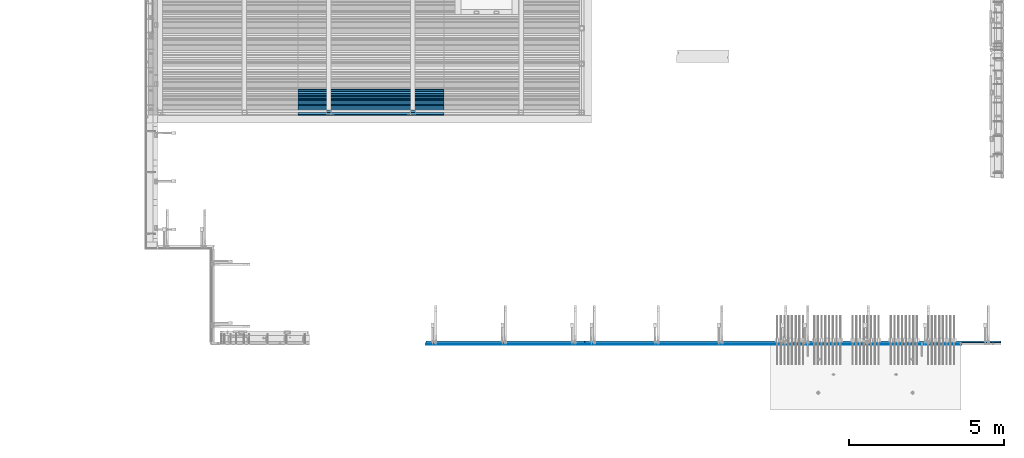
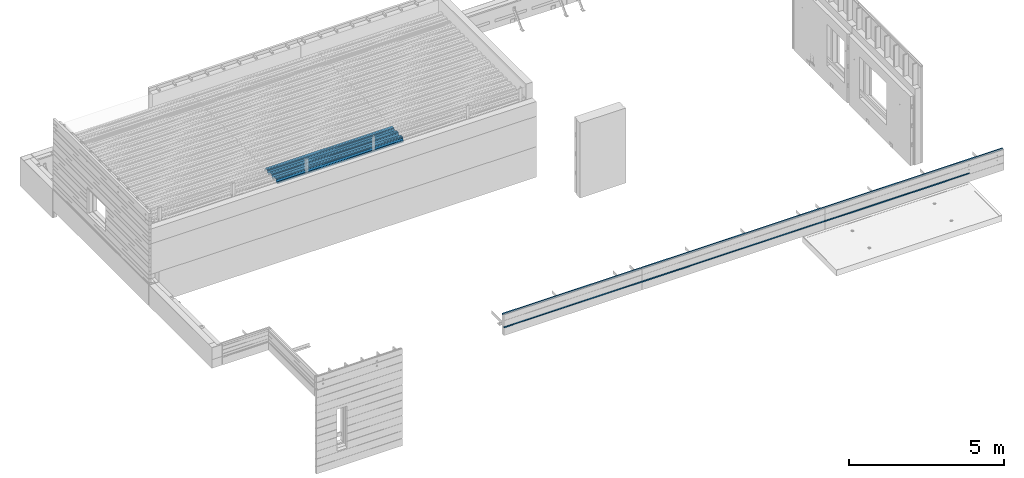
# One storey, part 19 of 153: 7 beams, 4 elements without a shape of their own.
"""IFC2X3 building model written with IfcOpenShell, lengths in millimetres."""

from ifc_helpers import new_model, si_unit, frame, origin_with_axes, place, context, subcontext, project, spatial, faceted_brep, material, type_object, element, aggregate, save


model = new_model("IFC2X3")

# Units and contexts
model_context = context("Model", 3, precision=1e-05, world=origin_with_axes())
body_context = subcontext(model_context, "Body", "Model", "MODEL_VIEW")
ifc_project = project(units=[si_unit("LENGTHUNIT", "METRE", prefix="MILLI"), si_unit("AREAUNIT", "SQUARE_METRE"), si_unit("VOLUMEUNIT", "CUBIC_METRE"), si_unit("MASSUNIT", "GRAM", prefix="KILO"), si_unit("TIMEUNIT", "SECOND"), si_unit("PLANEANGLEUNIT", "RADIAN"), si_unit("SOLIDANGLEUNIT", "STERADIAN"), si_unit("THERMODYNAMICTEMPERATUREUNIT", "DEGREE_CELSIUS"), si_unit("LUMINOUSINTENSITYUNIT", "LUMEN")], contexts=[model_context])

# Site, building, storey
site_placement = place(None, origin_with_axes())
site = spatial("IfcSite", under=ifc_project, at=site_placement, CompositionType="ELEMENT")
building_placement = place(site_placement, origin_with_axes())
building = spatial("IfcBuilding", under=site, at=building_placement, CompositionType="ELEMENT")
storey_placement = place(building_placement, origin_with_axes())
storey = spatial("IfcBuildingStorey", under=building, at=storey_placement, Name="8", CompositionType="ELEMENT", Elevation=0.0)

# Assembly, beam
assembly_1_placement = place(storey_placement, origin_with_axes())
assembly_1 = element("IfcElementAssembly", 1, at=assembly_1_placement, inside=storey, AssemblyPlace="NOTDEFINED", PredefinedType="REINFORCEMENT_UNIT")
ifc_material_1 = material(Name="TIMBER/T24")
beam_type_1 = type_object("IfcBeamType", PredefinedType="NOTDEFINED")
beam_1_placement = place(assembly_1_placement, frame((21800.0, 7562.5, 103080.0), z_axis=(0.0, -1.0, 0.0), x_axis=(-1.0, 3.00000001838171e-08, 0.0)))
beam_1 = element("IfcBeam", 2, at=beam_1_placement, type_object=beam_type_1, material=ifc_material_1, context=body_context, shape_type="Brep", body=[
    faceted_brep([(0.0, -25.0, -12.5), (5115.0, -25.0, -12.5), (5115.0, -6.41739461570978e-09, 12.5), (1.45519152283669e-11, -3.63797880709171e-12, 12.4999999999964), (0.0, 25.0, -12.5), (0.0, 25.0, 12.5), (5115.0, 25.0, 12.5), (5115.0, 25.0, -12.5)], [[[0, 1, 2, 3]], [[4, 5, 6, 7]], [[5, 4, 0, 3]], [[6, 5, 3, 2]], [[7, 6, 2, 1]], [[4, 7, 1, 0]]]),
])

assembly_2_placement = place(storey_placement, origin_with_axes())
assembly_2 = element("IfcElementAssembly", 3, at=assembly_2_placement, inside=storey, AssemblyPlace="NOTDEFINED", PredefinedType="REINFORCEMENT_UNIT")
beam_2_placement = place(assembly_2_placement, frame((28603.0, 7562.5, 103080.0), z_axis=(0.0, -1.0, 0.0), x_axis=(-1.0, 3.00000001838171e-08, 0.0)))
beam_2 = element("IfcBeam", 4, at=beam_2_placement, type_object=beam_type_1, material=ifc_material_1, context=body_context, shape_type="Brep", body=[
    faceted_brep([(0.0, -25.0, -12.5), (6788.0, -25.0, -12.5), (6788.0, -6.41739461570978e-09, 12.5), (1.45519152283669e-11, -3.63797880709171e-12, 12.4999999999964), (0.0, 25.0, -12.5), (0.0, 25.0, 12.5), (6788.0, 25.0, 12.5), (6788.0, 25.0, -12.5)], [[[0, 1, 2, 3]], [[4, 5, 6, 7]], [[5, 4, 0, 3]], [[6, 5, 3, 2]], [[7, 6, 2, 1]], [[4, 7, 1, 0]]]),
])

# Assembly, beams
assembly_3_placement = place(storey_placement, origin_with_axes())
assembly_3 = element("IfcElementAssembly", 5, at=assembly_3_placement, inside=storey, AssemblyPlace="NOTDEFINED", PredefinedType="REINFORCEMENT_UNIT")
beam_3_placement = place(assembly_3_placement, frame((33980.0, 7562.5, 103080.0), z_axis=(0.0, -1.0, 0.0), x_axis=(-1.0, 3.00000001838171e-08, 0.0)))
beam_3 = element("IfcBeam", 6, at=beam_3_placement, type_object=beam_type_1, material=ifc_material_1, context=body_context, shape_type="Brep", body=[
    faceted_brep([(0.0, -25.0, -12.5), (5363.0, -25.0, -12.5), (5363.0, -7.8580342233181e-09, 12.5), (1.45519152283669e-11, -3.63797880709171e-12, 12.4999999999964), (0.0, 25.0, -12.5), (0.0, 25.0, 12.5), (5363.0, 25.0, 12.5), (5363.0, 25.0, -12.5)], [[[0, 1, 2, 3]], [[4, 5, 6, 7]], [[5, 4, 0, 3]], [[6, 5, 3, 2]], [[7, 6, 2, 1]], [[4, 7, 1, 0]]]),
])
beam_type_2 = type_object("IfcBeamType", Name="PK50X50", PredefinedType="NOTDEFINED")
beam_4_placement = place(assembly_3_placement, frame((28617.0, 7640.0, 103545.0), z_axis=(0.0, 0.0, 1.0), x_axis=(1.0, 0.0, 0.0)))
beam_4 = element("IfcBeam", 7, at=beam_4_placement, type_object=beam_type_2, material=ifc_material_1, ObjectType="PK50X50", context=body_context, shape_type="Brep", body=[
    faceted_brep([(0.0, 25.0, 25.0), (0.0, -25.0, 25.0), (6643.0, -25.0, 25.0), (6643.0, 25.0, 25.0), (0.0, -25.0, -25.0), (6643.0, -25.0, -25.0), (0.0, 25.0, -25.0), (6643.0, 25.0, -25.0)], [[[0, 1, 2, 3]], [[1, 4, 5, 2]], [[4, 6, 7, 5]], [[6, 0, 3, 7]], [[5, 7, 3, 2]], [[4, 1, 0, 6]]]),
])
aggregate(assembly_3, [beam_3, beam_4])

# Beam
beam_5_placement = place(assembly_2_placement, frame((21815.0, 7640.0, 103545.0), z_axis=(0.0, 0.0, 1.0), x_axis=(1.0, 0.0, 0.0)))
beam_5 = element("IfcBeam", 8, at=beam_5_placement, type_object=beam_type_2, material=ifc_material_1, ObjectType="PK50X50", context=body_context, shape_type="Brep", body=[
    faceted_brep([(0.0, 25.0, 25.0), (0.0, -25.0, 25.0), (6788.0, -25.0, 25.0), (6788.0, 25.0, 25.0), (0.0, -25.0, -25.0), (6788.0, -25.0, -25.0), (0.0, 25.0, -25.0), (6788.0, 25.0, -25.0)], [[[0, 1, 2, 3]], [[1, 4, 5, 2]], [[4, 6, 7, 5]], [[6, 0, 3, 7]], [[5, 7, 3, 2]], [[4, 1, 0, 6]]]),
])

aggregate(assembly_2, [beam_2, beam_5])

beam_6_placement = place(assembly_1_placement, frame((16685.0, 7640.0, 103545.0), z_axis=(0.0, 0.0, 1.0), x_axis=(1.0, 0.0, 0.0)))
beam_6 = element("IfcBeam", 9, at=beam_6_placement, type_object=beam_type_2, material=ifc_material_1, ObjectType="PK50X50", context=body_context, shape_type="Brep", body=[
    faceted_brep([(0.0, 25.0, 25.0), (0.0, -25.0, 25.0), (5115.0, -25.0, 25.0), (5115.0, 25.0, 25.0), (0.0, -25.0, -25.0), (5115.0, -25.0, -25.0), (0.0, 25.0, -25.0), (5115.0, 25.0, -25.0)], [[[0, 1, 2, 3]], [[1, 4, 5, 2]], [[4, 6, 7, 5]], [[6, 0, 3, 7]], [[5, 7, 3, 2]], [[4, 1, 0, 6]]]),
])

aggregate(assembly_1, [beam_1, beam_6])

# Assembly, beam
assembly_4_placement = place(storey_placement, origin_with_axes())
assembly_4 = element("IfcElementAssembly", 10, at=assembly_4_placement, inside=storey, Name="Steel Assembly", AssemblyPlace="NOTDEFINED", PredefinedType="RIGID_FRAME")
ifc_material_2 = material(Name="STEEL/S355J2")
beam_type_3 = type_object("IfcBeamType", Name="W", PredefinedType="NOTDEFINED")
beam_7_placement = place(assembly_4_placement, frame((17251.9999999917, 15385.2090542417, 105749.900488301), z_axis=(0.0, -0.0124990270013869, 0.999921884110963), x_axis=(-1.0, 3.00000001838171e-08, 0.0)))
beam_7 = element("IfcBeam", 11, at=beam_7_placement, type_object=beam_type_3, material=ifc_material_2, ObjectType="W", context=body_context, shape_type="Brep", body=[
    faceted_brep([(0.0, -412.839996337891, -77.0100021362159), (0.0, -409.160003662109, -77.0100021362014), (4717.0, -409.160003662109, -77.0100021362159), (4717.0, -412.839996337891, -77.0100021362159), (0.0, -408.070007324222, -73.4800033569045), (4717.0, -408.070007324222, -73.480003356919), (0.0, -400.339996337894, -48.0600013732619), (4717.0, -400.339996337894, -48.0600013732765), (0.0, -399.459991455082, -46.5600013732619), (4717.0, -399.459991455078, -46.5600013732765), (0.0, -390.329986572269, -36.5499992370314), (4717.0, -390.329986572266, -36.549999237046), (0.0, -389.19000244141, -34.6300010680861), (4717.0, -389.190002441403, -34.6300010681007), (0.0, -367.820007324222, 35.3400001526024), (4717.0, -367.820007324219, 35.3400001525879), (0.0, -366.989990234379, 36.8499984741502), (4717.0, -366.989990234375, 36.8499984741356), (0.0, -357.809997558597, 46.8600006103807), (4717.0, -357.809997558594, 46.8600006103661), (0.0, -356.720001220707, 48.7700004577782), (4717.0, -356.720001220703, 48.7700004577782), (0.0, -349.309997558594, 73.1500015258935), (4717.0, -349.309997558594, 73.1500015258935), (0.0, -347.850006103516, 75.2300033569481), (4717.0, -347.850006103516, 75.2300033569481), (0.0, -345.470001220707, 76.010002136245), (4717.0, -345.470001220703, 76.0100021362305), (0.0, -305.480010986332, 76.010002136245), (4717.0, -305.480010986324, 76.0100021362305), (0.0, -304.279998779301, 75.8000030517578), (4717.0, -304.279998779301, 75.8000030517724), (0.0, -291.679992675785, 71.6999969482567), (4717.0, -291.679992675785, 71.6999969482567), (0.0, -290.179992675789, 71.2300033569481), (4717.0, -290.179992675781, 71.2300033569481), (0.0, -288.720001220707, 71.6999969482567), (4717.0, -288.720001220703, 71.6999969482422), (0.0, -276.119995117191, 75.8000030517869), (4717.0, -276.119995117188, 75.8000030517724), (0.0, -274.929992675785, 76.010002136245), (4717.0, -274.929992675785, 76.010002136245), (0.0, -234.94000244141, 76.010002136245), (4717.0, -234.94000244141, 76.010002136245), (0.0, -232.550003051758, 75.2300033569627), (4717.0, -232.550003051758, 75.2300033569481), (0.0, -231.100006103519, 73.1500015258935), (4717.0, -231.100006103516, 73.1500015258789), (0.0, -223.679992675785, 48.7700004577782), (4717.0, -223.679992675781, 48.7700004577782), (0.0, -222.589996337894, 46.8600006103661), (4717.0, -222.589996337891, 46.8600006103516), (0.0, -213.410003662113, 36.8499984741502), (4717.0, -213.410003662109, 36.8499984741356), (0.0, -212.529998779301, 35.3400001526024), (4717.0, -212.529998779297, 35.3400001526024), (0.0, -191.160003662109, -34.6300010681007), (4717.0, -191.160003662109, -34.6300010681007), (0.0, -190.070007324222, -36.5499992370605), (4717.0, -190.070007324215, -36.549999237046), (0.0, -180.940002441406, -46.560001373291), (4717.0, -180.940002441406, -46.5600013732765), (0.0, -180.059997558597, -48.0600013732619), (4717.0, -180.059997558594, -48.0600013732765), (0.0, -172.330001831055, -73.480003356919), (4717.0, -172.330001831055, -73.480003356919), (0.0, -171.240005493168, -77.0100021362159), (4717.0, -171.240005493164, -77.0100021362159), (0.0, -129.330001831062, -77.0100021362014), (4717.0, -129.330001831055, -77.0100021362159), (0.0, -128.300003051761, -73.480003356919), (4717.0, -128.300003051758, -73.4800033569336), (0.0, -120.51999664307, -48.0600013732765), (4717.0, -120.519996643063, -48.0600013732765), (0.0, -119.629997253418, -46.5600013732765), (4717.0, -119.629997253418, -46.5600013732765), (0.0, -110.500000000004, -36.5499992370314), (4717.0, -110.5, -36.549999237046), (0.0, -109.419998168949, -34.6300010680861), (4717.0, -109.419998168945, -34.6300010681007), (0.0, -88.0500030517615, 35.3400001526024), (4717.0, -88.0500030517578, 35.3400001526024), (0.0, -87.160003662113, 36.8499984741356), (4717.0, -87.160003662113, 36.8499984741356), (0.0, -78.0400009155273, 46.8600006103807), (4717.0, -78.0400009155273, 46.8600006103661), (0.0, -76.8899993896557, 48.7700004577782), (4717.0, -76.8899993896521, 48.7700004577782), (0.0, -69.4800033569336, 73.1500015258935), (4717.0, -69.4800033569336, 73.1500015258935), (0.0, -68.0299987793042, 75.2300033569336), (4717.0, -68.0299987792969, 75.2300033569481), (0.0, -65.6399993896521, 76.010002136245), (4717.0, -65.6399993896484, 76.010002136245), (0.0, -25.6499996185375, 76.0100021362596), (4717.0, -25.6499996185303, 76.010002136245), (0.0, -24.5100002288891, 75.8000030517724), (4717.0, -24.5100002288818, 75.8000030517724), (0.0, -11.8500003814697, 71.6999969482567), (4717.0, -11.8500003814661, 71.6999969482567), (0.0, -10.3999996185339, 71.2300033569481), (4717.0, -10.3999996185303, 71.2300033569336), (0.0, -8.89999961853391, 71.6999969482567), (4717.0, -8.89999961853391, 71.6999969482567), (0.0, 3.71000003814333, 75.8000030517724), (4717.0, 3.71000003814697, 75.8000030517869), (0.0, 4.90000009536379, 76.0100021362596), (4717.0, 4.90000009536379, 76.010002136245), (0.0, 44.8899993896484, 76.010002136245), (4717.0, 44.8899993896484, 76.010002136245), (0.0, 47.2799987792932, 75.2300033569481), (4717.0, 47.2799987792969, 75.2300033569481), (0.0, 48.6800003051721, 73.1500015258935), (4717.0, 48.6800003051758, 73.1500015258789), (0.0, 56.1500015258753, 48.7700004577782), (4717.0, 56.1500015258789, 48.7700004577782), (0.0, 57.2400016784632, 46.8600006103807), (4717.0, 57.2400016784632, 46.8600006103661), (0.0, 66.3700027465784, 36.8499984741211), (4717.0, 66.3700027465857, 36.8499984741356), (0.0, 67.2499999999964, 35.3400001526024), (4717.0, 67.2500000000036, 35.3400001526024), (0.0, 88.6200027465748, -34.6300010681007), (4717.0, 88.620002746582, -34.6300010681152), (0.0, 89.709999084469, -36.549999237046), (4717.0, 89.7099990844727, -36.5499992370605), (0.0, 98.8899993896412, -46.5600013732765), (4717.0, 98.8899993896484, -46.5600013732765), (0.0, 99.7699966430628, -48.0600013732765), (4717.0, 99.7699966430664, -48.060001373291), (0.0, 107.499999999996, -73.4800033569336), (4717.0, 107.5, -73.480003356919), (0.0, 108.589996337887, -77.0100021362014), (4717.0, 108.589996337894, -77.0100021362159), (0.0, 112.269996643063, -77.0100021362159), (4717.0, 112.269996643066, -77.0100021362159), (0.0, 146.759994506836, -77.0100021362159), (4717.0, 146.759994506836, -77.0100021362159), (0.0, 150.440002441403, -77.0100021362159), (4717.0, 150.440002441403, -77.0100021362305), (0.0, 151.529998779297, -73.480003356919), (4717.0, 151.529998779297, -73.4800033569336), (0.0, 159.30999755859, -48.0600013732765), (4717.0, 159.309997558594, -48.0600013732765), (0.0, 160.190002441406, -46.5600013732619), (4717.0, 160.190002441406, -46.5600013732765), (0.0, 169.320007324215, -36.549999237046), (4717.0, 169.320007324222, -36.5499992370605), (0.0, 170.410003662106, -34.6300010680861), (4717.0, 170.410003662109, -34.6300010681007), (0.0, 191.779998779293, 35.3400001526024), (4717.0, 191.779998779293, 35.3400001526024), (0.0, 192.660003662109, 36.8499984741502), (4717.0, 192.660003662109, 36.8499984741356), (0.0, 201.789993286129, 46.8600006103661), (4717.0, 201.789993286133, 46.8600006103661), (0.0, 202.880004882809, 48.7700004577637), (4717.0, 202.880004882813, 48.7700004577782), (0.0, 210.350006103512, 73.150001525908), (4717.0, 210.350006103516, 73.1500015258935), (0.0, 211.800003051754, 75.2300033569481), (4717.0, 211.800003051758, 75.2300033569336), (0.0, 214.190002441406, 76.010002136245), (4717.0, 214.19000244141, 76.010002136245), (0.0, 254.179992675778, 76.010002136245), (4717.0, 254.179992675778, 76.010002136245), (0.0, 255.320007324215, 75.8000030517869), (4717.0, 255.320007324222, 75.8000030517724), (0.0, 267.980010986324, 71.6999969482713), (4717.0, 267.980010986328, 71.6999969482567), (0.0, 269.429992675778, 71.2300033569481), (4717.0, 269.429992675781, 71.2300033569481), (0.0, 270.880004882809, 71.6999969482567), (4717.0, 270.880004882813, 71.6999969482567), (0.0, 283.540008544918, 75.8000030517869), (4717.0, 283.540008544918, 75.8000030517724), (0.0, 284.679992675778, 76.010002136245), (4717.0, 284.679992675778, 76.010002136245), (0.0, 324.670013427731, 76.010002136245), (4717.0, 324.670013427738, 76.010002136245), (0.0, 327.049987792969, 75.2300033569627), (4717.0, 327.049987792969, 75.2300033569481), (0.0, 328.510009765625, 73.1500015258789), (4717.0, 328.510009765625, 73.1500015258935), (0.0, 335.980010986324, 48.7700004577782), (4717.0, 335.980010986328, 48.7700004577782), (0.0, 337.05999755859, 46.8600006103661), (4717.0, 337.059997558594, 46.8600006103516), (0.0, 346.190002441399, 36.8499984741356), (4717.0, 346.190002441406, 36.8499984741211), (0.0, 347.079986572266, 35.3400001526024), (4717.0, 347.079986572266, 35.3400001526024), (0.0, 368.450012207028, -34.6300010680861), (4717.0, 368.450012207035, -34.6300010681007), (0.0, 369.529998779293, -36.5499992370314), (4717.0, 369.529998779297, -36.549999237046), (0.0, 378.660003662106, -46.5600013732619), (4717.0, 378.660003662106, -46.5600013732765), (0.0, 379.540008544918, -48.0600013732619), (4717.0, 379.540008544922, -48.0600013732765), (0.0, 387.329986572262, -73.480003356919), (4717.0, 387.329986572266, -73.4800033569045), (0.0, 388.410003662109, -77.0100021362159), (4717.0, 388.410003662109, -77.0100021362159), (0.0, 392.100006103512, -77.0100021362159), (4717.0, 392.100006103519, -77.0100021362159), (0.0, 426.589996337887, -77.0100021362159), (4717.0, 426.589996337891, -77.0100021362159), (0.0, 430.269989013668, -77.0100021362159), (4717.0, 430.269989013672, -77.0100021362305), (0.0, 431.359985351559, -73.4800033569045), (4717.0, 431.359985351563, -73.480003356919), (0.0, 433.179992675778, -67.5699996948097), (4717.0, 433.179992675781, -67.5699996948097), (0.0, 432.220001220699, -67.2699966430373), (4717.0, 432.220001220703, -67.2699966430519), (0.0, 430.410003662106, -73.1800003051612), (4717.0, 430.410003662106, -73.1800003051758), (0.0, 429.529998779293, -76.0100021362159), (4717.0, 429.529998779293, -76.0100021362159), (0.0, 426.589996337891, -76.0100021362159), (4717.0, 426.589996337891, -76.0100021362159), (0.0, 392.100006103512, -76.0100021362159), (4717.0, 392.100006103516, -76.0100021362159), (0.0, 389.149993896481, -76.0100021362014), (4717.0, 389.149993896484, -76.0100021362159), (0.0, 388.279998779293, -73.1800003051467), (4717.0, 388.279998779301, -73.1800003051612), (0.0, 380.470001220699, -47.659999847383), (4717.0, 380.470001220703, -47.6599998473976), (0.0, 379.470001220699, -45.9599990844436), (4717.0, 379.470001220703, -45.9599990844581), (0.0, 370.350006103512, -35.9599990844581), (4717.0, 370.350006103519, -35.9599990844581), (0.0, 369.369995117184, -34.2299995422218), (4717.0, 369.369995117184, -34.2299995422218), (0.0, 347.999999999996, 35.7500000000146), (4717.0, 348.0, 35.7500000000146), (0.0, 346.999999999996, 37.4399986267235), (4717.0, 347.000000000004, 37.4399986267235), (0.0, 337.880004882809, 47.450000762954), (4717.0, 337.880004882809, 47.4500007629395), (0.0, 336.899993896481, 49.1699981689453), (4717.0, 336.899993896484, 49.1699981689599), (0.0, 329.420013427731, 73.5999984741356), (4717.0, 329.420013427734, 73.5999984741356), (0.0, 327.679992675781, 76.0699996948533), (4717.0, 327.679992675781, 76.0699996948388), (0.0, 324.829986572262, 77.010002136245), (4717.0, 324.829986572266, 77.0100021362305), (0.0, 284.589996337887, 77.010002136245), (4717.0, 284.589996337891, 77.010002136245), (0.0, 283.290008544922, 76.769996643081), (4717.0, 283.290008544922, 76.769996643081), (0.0, 270.570007324215, 72.6500015258935), (4717.0, 270.570007324219, 72.6500015258935), (0.0, 269.429992675781, 72.2799987793114), (4717.0, 269.429992675781, 72.2799987793114), (0.0, 268.279998779293, 72.650001525908), (4717.0, 268.279998779297, 72.6500015258935), (0.0, 255.570007324219, 76.769996643081), (4717.0, 255.570007324219, 76.769996643081), (0.0, 254.270004272461, 77.0100021362596), (4717.0, 254.270004272461, 77.010002136245), (0.0, 214.029998779293, 77.0100021362596), (4717.0, 214.029998779297, 77.010002136245), (0.0, 211.179992675781, 76.0699996948388), (4717.0, 211.179992675781, 76.0699996948533), (0.0, 209.440002441403, 73.5999984741356), (4717.0, 209.44000244141, 73.5999984741211), (0.0, 201.960006713864, 49.1699981689599), (4717.0, 201.960006713867, 49.1699981689453), (0.0, 200.979995727532, 47.450000762954), (4717.0, 200.979995727539, 47.4500007629395), (0.0, 191.850006103508, 37.4399986267235), (4717.0, 191.850006103516, 37.439998626709), (0.0, 190.860000610352, 35.7500000000146), (4717.0, 190.860000610352, 35.75), (0.0, 169.49000549316, -34.2299995422218), (4717.0, 169.49000549316, -34.2299995422363), (0.0, 168.509994506832, -35.9599990844581), (4717.0, 168.509994506836, -35.9599990844581), (0.0, 159.380004882805, -45.9599990844436), (4717.0, 159.380004882813, -45.9599990844581), (0.0, 158.389999389645, -47.6599998473976), (4717.0, 158.389999389645, -47.6599998474121), (0.0, 150.580001831051, -73.1800003051612), (4717.0, 150.580001831058, -73.1800003051758), (0.0, 149.710006713864, -76.0100021362159), (4717.0, 149.710006713867, -76.0100021362159), (0.0, 146.759994506836, -76.0100021362159), (4717.0, 146.759994506836, -76.0100021362159), (0.0, 112.269996643063, -76.0100021362159), (4717.0, 112.269996643063, -76.0100021362159), (0.0, 109.319999694821, -76.0100021362159), (4717.0, 109.319999694821, -76.0100021362159), (0.0, 108.449996948239, -73.1900024413917), (4717.0, 108.449996948242, -73.1900024414063), (0.0, 100.690002441406, -47.659999847383), (4717.0, 100.69000244141, -47.6599998473976), (0.0, 99.6999969482386, -45.9599990844581), (4717.0, 99.6999969482422, -45.9599990844581), (0.0, 90.5199966430664, -35.9599990844581), (4717.0, 90.5199966430664, -35.9599990844727), (0.0, 89.5400009155273, -34.2299995422218), (4717.0, 89.5400009155273, -34.2299995422218), (0.0, 68.1699981689417, 35.7500000000146), (4717.0, 68.1699981689453, 35.7500000000146), (0.0, 67.1699981689417, 37.4399986267235), (4717.0, 67.1699981689453, 37.4399986267235), (0.0, 58.0499992370569, 47.4500007629686), (4717.0, 58.0499992370605, 47.450000762954), (0.0, 57.0699996948206, 49.1699981689599), (4717.0, 57.0699996948279, 49.1699981689453), (0.0, 49.5900001525843, 73.5899963379052), (4717.0, 49.5900001525879, 73.5899963378906), (0.0, 47.9099998474085, 76.0699996948388), (4717.0, 47.9099998474121, 76.0699996948242), (0.0, 45.0499992370569, 77.010002136245), (4717.0, 45.0499992370605, 77.010002136245), (0.0, 4.82000017165774, 77.010002136245), (4717.0, 4.82000017166138, 77.010002136245), (0.0, 3.47000002860659, 76.7699966430955), (4717.0, 3.47000002860659, 76.769996643081), (0.0, -9.19999980926514, 72.6500015258935), (4717.0, -9.19999980926514, 72.6500015258789), (0.0, -10.3900003433264, 72.2799987792969), (4717.0, -10.3900003433228, 72.2799987793114), (0.0, -11.5399999618567, 72.6500015258935), (4717.0, -11.5399999618494, 72.6500015258935), (0.0, -24.2600002288855, 76.769996643081), (4717.0, -24.2600002288818, 76.769996643081), (0.0, -25.559999465946, 77.0100021362596), (4717.0, -25.5599994659424, 77.010002136245), (0.0, -65.8000030517615, 77.0100021362596), (4717.0, -65.8000030517578, 77.010002136245), (0.0, -68.6500015258862, 76.0699996948533), (4717.0, -68.6500015258825, 76.0699996948388), (0.0, -70.3899993896521, 73.5999984741356), (4717.0, -70.3899993896484, 73.5999984741211), (0.0, -77.8199996948242, 49.1800003051903), (4717.0, -77.8199996948242, 49.1800003051903), (0.0, -78.8399963378943, 47.450000762954), (4717.0, -78.8399963378906, 47.4500007629395), (0.0, -87.9700012207031, 37.4399986267235), (4717.0, -87.9700012207031, 37.4399986267235), (0.0, -88.9700012207068, 35.7500000000146), (4717.0, -88.9700012207031, 35.75), (0.0, -110.339996337894, -34.2299995422218), (4717.0, -110.339996337887, -34.2299995422218), (0.0, -111.319999694828, -35.9599990844581), (4717.0, -111.319999694824, -35.9599990844581), (0.0, -120.440002441406, -45.9599990844436), (4717.0, -120.440002441406, -45.9599990844581), (0.0, -121.44000244141, -47.6599998473976), (4717.0, -121.440002441403, -47.6599998473976), (0.0, -129.250000000004, -73.1900024413771), (4717.0, -129.25, -73.1900024413917), (0.0, -130.080001831062, -76.0100021362159), (4717.0, -130.080001831055, -76.0100021362159), (0.0, -170.5, -76.0100021362014), (4717.0, -170.5, -76.0100021362159), (0.0, -171.380004882816, -73.1900024413917), (4717.0, -171.380004882813, -73.1900024414063), (0.0, -179.139999389652, -47.6599998473976), (4717.0, -179.139999389648, -47.6599998473976), (0.0, -180.130004882816, -45.9599990844581), (4717.0, -180.130004882813, -45.9599990844581), (0.0, -189.259994506836, -35.9599990844581), (4717.0, -189.259994506832, -35.9599990844581), (0.0, -190.240005493168, -34.2299995422218), (4717.0, -190.240005493164, -34.2299995422218), (0.0, -211.610000610355, 35.7500000000146), (4717.0, -211.610000610352, 35.7500000000146), (0.0, -212.600006103519, 37.4399986267381), (4717.0, -212.600006103519, 37.4399986267235), (0.0, -221.779998779301, 47.450000762954), (4717.0, -221.779998779293, 47.4500007629395), (0.0, -222.75999450684, 49.1699981689599), (4717.0, -222.759994506836, 49.1699981689599), (0.0, -230.190002441406, 73.5999984741356), (4717.0, -230.190002441406, 73.5999984741211), (0.0, -231.919998168945, 76.0699996948388), (4717.0, -231.919998168945, 76.0699996948388), (0.0, -234.779998779301, 77.010002136245), (4717.0, -234.779998779293, 77.010002136245), (0.0, -275.010009765629, 77.010002136245), (4717.0, -275.010009765625, 77.0100021362305), (0.0, -276.359985351563, 76.769996643081), (4717.0, -276.359985351563, 76.7699966430664), (0.0, -289.029998779297, 72.6500015258789), (4717.0, -289.029998779297, 72.6500015258935), (0.0, -290.179992675785, 72.2799987793114), (4717.0, -290.179992675785, 72.2799987793114), (0.0, -291.380004882816, 72.650001525908), (4717.0, -291.380004882813, 72.6500015258935), (0.0, -304.040008544926, 76.769996643081), (4717.0, -304.040008544918, 76.769996643081), (0.0, -305.390014648441, 77.010002136245), (4717.0, -305.390014648438, 77.010002136245), (0.0, -345.63000488282, 77.0100021362596), (4717.0, -345.630004882813, 77.010002136245), (0.0, -348.480010986332, 76.0699996948388), (4717.0, -348.480010986324, 76.0699996948388), (0.0, -350.220001220707, 73.5999984741356), (4717.0, -350.220001220703, 73.5999984741211), (0.0, -357.649993896492, 49.1699981689599), (4717.0, -357.649993896484, 49.1699981689744), (0.0, -358.63000488282, 47.450000762954), (4717.0, -358.630004882813, 47.450000762954), (0.0, -367.809997558594, 37.4300003051903), (4717.0, -367.809997558594, 37.4300003051903), (0.0, -368.750000000004, 35.7299995422654), (4717.0, -368.75, 35.7299995422509), (0.0, -390.109985351566, -34.2200012207031), (4717.0, -390.109985351563, -34.2200012206886), (0.0, -391.140014648441, -35.9500007629249), (4717.0, -391.140014648438, -35.9500007629103), (0.0, -400.269989013676, -45.9599990844436), (4717.0, -400.269989013672, -45.9599990844581), (0.0, -401.269989013672, -47.6599998473976), (4717.0, -401.269989013672, -47.6599998473976), (0.0, -409.029998779297, -73.1900024413917), (4717.0, -409.029998779297, -73.1900024413917), (0.0, -409.899993896488, -76.0100021362159), (4717.0, -409.899993896481, -76.0100021362305), (0.0, -412.839996337891, -76.0100021362159), (4717.0, -412.839996337891, -76.0100021362305), (0.0, -433.179992675785, -76.0100021362159), (4717.0, -433.179992675781, -76.0100021362159), (0.0, -433.179992675785, -77.0100021362159), (4717.0, -433.179992675785, -77.0100021362305)], [[[0, 1, 2, 3]], [[1, 4, 5, 2]], [[4, 6, 7, 5]], [[6, 8, 9, 7]], [[8, 10, 11, 9]], [[10, 12, 13, 11]], [[12, 14, 15, 13]], [[14, 16, 17, 15]], [[16, 18, 19, 17]], [[18, 20, 21, 19]], [[20, 22, 23, 21]], [[22, 24, 25, 23]], [[24, 26, 27, 25]], [[26, 28, 29, 27]], [[28, 30, 31, 29]], [[30, 32, 33, 31]], [[32, 34, 35, 33]], [[34, 36, 37, 35]], [[36, 38, 39, 37]], [[38, 40, 41, 39]], [[40, 42, 43, 41]], [[42, 44, 45, 43]], [[44, 46, 47, 45]], [[46, 48, 49, 47]], [[48, 50, 51, 49]], [[50, 52, 53, 51]], [[52, 54, 55, 53]], [[54, 56, 57, 55]], [[56, 58, 59, 57]], [[58, 60, 61, 59]], [[60, 62, 63, 61]], [[62, 64, 65, 63]], [[64, 66, 67, 65]], [[66, 68, 69, 67]], [[68, 70, 71, 69]], [[70, 72, 73, 71]], [[72, 74, 75, 73]], [[74, 76, 77, 75]], [[76, 78, 79, 77]], [[78, 80, 81, 79]], [[80, 82, 83, 81]], [[82, 84, 85, 83]], [[84, 86, 87, 85]], [[86, 88, 89, 87]], [[88, 90, 91, 89]], [[90, 92, 93, 91]], [[92, 94, 95, 93]], [[94, 96, 97, 95]], [[96, 98, 99, 97]], [[98, 100, 101, 99]], [[100, 102, 103, 101]], [[102, 104, 105, 103]], [[104, 106, 107, 105]], [[106, 108, 109, 107]], [[108, 110, 111, 109]], [[110, 112, 113, 111]], [[112, 114, 115, 113]], [[114, 116, 117, 115]], [[116, 118, 119, 117]], [[118, 120, 121, 119]], [[120, 122, 123, 121]], [[122, 124, 125, 123]], [[124, 126, 127, 125]], [[126, 128, 129, 127]], [[128, 130, 131, 129]], [[130, 132, 133, 131]], [[132, 134, 135, 133]], [[134, 136, 137, 135]], [[136, 138, 139, 137]], [[138, 140, 141, 139]], [[140, 142, 143, 141]], [[142, 144, 145, 143]], [[144, 146, 147, 145]], [[146, 148, 149, 147]], [[148, 150, 151, 149]], [[150, 152, 153, 151]], [[152, 154, 155, 153]], [[154, 156, 157, 155]], [[156, 158, 159, 157]], [[158, 160, 161, 159]], [[160, 162, 163, 161]], [[162, 164, 165, 163]], [[164, 166, 167, 165]], [[166, 168, 169, 167]], [[168, 170, 171, 169]], [[170, 172, 173, 171]], [[172, 174, 175, 173]], [[174, 176, 177, 175]], [[176, 178, 179, 177]], [[178, 180, 181, 179]], [[180, 182, 183, 181]], [[182, 184, 185, 183]], [[184, 186, 187, 185]], [[186, 188, 189, 187]], [[188, 190, 191, 189]], [[190, 192, 193, 191]], [[192, 194, 195, 193]], [[194, 196, 197, 195]], [[196, 198, 199, 197]], [[198, 200, 201, 199]], [[200, 202, 203, 201]], [[202, 204, 205, 203]], [[204, 206, 207, 205]], [[206, 208, 209, 207]], [[208, 210, 211, 209]], [[210, 212, 213, 211]], [[212, 214, 215, 213]], [[214, 216, 217, 215]], [[216, 218, 219, 217]], [[218, 220, 221, 219]], [[220, 222, 223, 221]], [[222, 224, 225, 223]], [[224, 226, 227, 225]], [[226, 228, 229, 227]], [[228, 230, 231, 229]], [[230, 232, 233, 231]], [[232, 234, 235, 233]], [[234, 236, 237, 235]], [[236, 238, 239, 237]], [[238, 240, 241, 239]], [[240, 242, 243, 241]], [[242, 244, 245, 243]], [[244, 246, 247, 245]], [[246, 248, 249, 247]], [[248, 250, 251, 249]], [[250, 252, 253, 251]], [[252, 254, 255, 253]], [[254, 256, 257, 255]], [[256, 258, 259, 257]], [[258, 260, 261, 259]], [[260, 262, 263, 261]], [[262, 264, 265, 263]], [[264, 266, 267, 265]], [[266, 268, 269, 267]], [[268, 270, 271, 269]], [[270, 272, 273, 271]], [[272, 274, 275, 273]], [[274, 276, 277, 275]], [[276, 278, 279, 277]], [[278, 280, 281, 279]], [[280, 282, 283, 281]], [[282, 284, 285, 283]], [[284, 286, 287, 285]], [[286, 288, 289, 287]], [[288, 290, 291, 289]], [[290, 292, 293, 291]], [[292, 294, 295, 293]], [[294, 296, 297, 295]], [[296, 298, 299, 297]], [[298, 300, 301, 299]], [[300, 302, 303, 301]], [[302, 304, 305, 303]], [[304, 306, 307, 305]], [[306, 308, 309, 307]], [[308, 310, 311, 309]], [[310, 312, 313, 311]], [[312, 314, 315, 313]], [[314, 316, 317, 315]], [[316, 318, 319, 317]], [[318, 320, 321, 319]], [[320, 322, 323, 321]], [[322, 324, 325, 323]], [[324, 326, 327, 325]], [[326, 328, 329, 327]], [[328, 330, 331, 329]], [[330, 332, 333, 331]], [[332, 334, 335, 333]], [[334, 336, 337, 335]], [[336, 338, 339, 337]], [[338, 340, 341, 339]], [[340, 342, 343, 341]], [[342, 344, 345, 343]], [[344, 346, 347, 345]], [[346, 348, 349, 347]], [[348, 350, 351, 349]], [[350, 352, 353, 351]], [[352, 354, 355, 353]], [[354, 356, 357, 355]], [[356, 358, 359, 357]], [[358, 360, 361, 359]], [[360, 362, 363, 361]], [[362, 364, 365, 363]], [[364, 366, 367, 365]], [[366, 368, 369, 367]], [[368, 370, 371, 369]], [[370, 372, 373, 371]], [[372, 374, 375, 373]], [[374, 376, 377, 375]], [[376, 378, 379, 377]], [[378, 380, 381, 379]], [[380, 382, 383, 381]], [[382, 384, 385, 383]], [[384, 386, 387, 385]], [[386, 388, 389, 387]], [[388, 390, 391, 389]], [[390, 392, 393, 391]], [[392, 394, 395, 393]], [[394, 396, 397, 395]], [[396, 398, 399, 397]], [[398, 400, 401, 399]], [[400, 402, 403, 401]], [[402, 404, 405, 403]], [[404, 406, 407, 405]], [[406, 408, 409, 407]], [[408, 410, 411, 409]], [[410, 412, 413, 411]], [[412, 414, 415, 413]], [[414, 416, 417, 415]], [[416, 418, 419, 417]], [[418, 420, 421, 419]], [[420, 422, 423, 421]], [[422, 424, 425, 423]], [[424, 426, 427, 425]], [[426, 428, 429, 427]], [[428, 430, 431, 429]], [[430, 0, 3, 431]], [[5, 7, 9, 11, 13, 15, 17, 19, 21, 23, 25, 27, 29, 31, 33, 35, 37, 39, 41, 43, 45, 47, 49, 51, 53, 55, 57, 59, 61, 63, 65, 67, 69, 71, 73, 75, 77, 79, 81, 83, 85, 87, 89, 91, 93, 95, 97, 99, 101, 103, 105, 107, 109, 111, 113, 115, 117, 119, 121, 123, 125, 127, 129, 131, 133, 135, 137, 139, 141, 143, 145, 147, 149, 151, 153, 155, 157, 159, 161, 163, 165, 167, 169, 171, 173, 175, 177, 179, 181, 183, 185, 187, 189, 191, 193, 195, 197, 199, 201, 203, 205, 207, 209, 211, 213, 215, 217, 219, 221, 223, 225, 227, 229, 231, 233, 235, 237, 239, 241, 243, 245, 247, 249, 251, 253, 255, 257, 259, 261, 263, 265, 267, 269, 271, 273, 275, 277, 279, 281, 283, 285, 287, 289, 291, 293, 295, 297, 299, 301, 303, 305, 307, 309, 311, 313, 315, 317, 319, 321, 323, 325, 327, 329, 331, 333, 335, 337, 339, 341, 343, 345, 347, 349, 351, 353, 355, 357, 359, 361, 363, 365, 367, 369, 371, 373, 375, 377, 379, 381, 383, 385, 387, 389, 391, 393, 395, 397, 399, 401, 403, 405, 407, 409, 411, 413, 415, 417, 419, 421, 423, 425, 427, 429, 431, 3, 2]], [[430, 428, 426, 424, 422, 420, 418, 416, 414, 412, 410, 408, 406, 404, 402, 400, 398, 396, 394, 392, 390, 388, 386, 384, 382, 380, 378, 376, 374, 372, 370, 368, 366, 364, 362, 360, 358, 356, 354, 352, 350, 348, 346, 344, 342, 340, 338, 336, 334, 332, 330, 328, 326, 324, 322, 320, 318, 316, 314, 312, 310, 308, 306, 304, 302, 300, 298, 296, 294, 292, 290, 288, 286, 284, 282, 280, 278, 276, 274, 272, 270, 268, 266, 264, 262, 260, 258, 256, 254, 252, 250, 248, 246, 244, 242, 240, 238, 236, 234, 232, 230, 228, 226, 224, 222, 220, 218, 216, 214, 212, 210, 208, 206, 204, 202, 200, 198, 196, 194, 192, 190, 188, 186, 184, 182, 180, 178, 176, 174, 172, 170, 168, 166, 164, 162, 160, 158, 156, 154, 152, 150, 148, 146, 144, 142, 140, 138, 136, 134, 132, 130, 128, 126, 124, 122, 120, 118, 116, 114, 112, 110, 108, 106, 104, 102, 100, 98, 96, 94, 92, 90, 88, 86, 84, 82, 80, 78, 76, 74, 72, 70, 68, 66, 64, 62, 60, 58, 56, 54, 52, 50, 48, 46, 44, 42, 40, 38, 36, 34, 32, 30, 28, 26, 24, 22, 20, 18, 16, 14, 12, 10, 8, 6, 4, 1, 0]]]),
])
aggregate(assembly_4, [beam_7])

save(model, "model.ifc")
